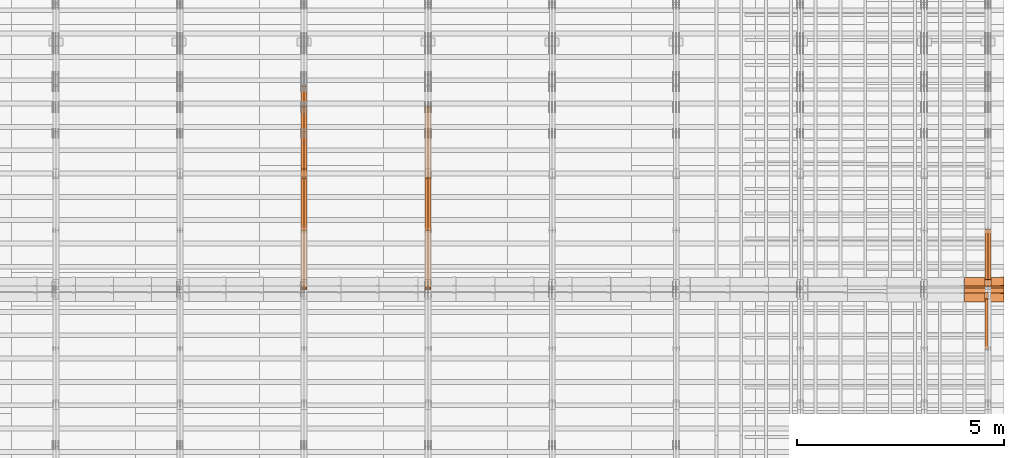
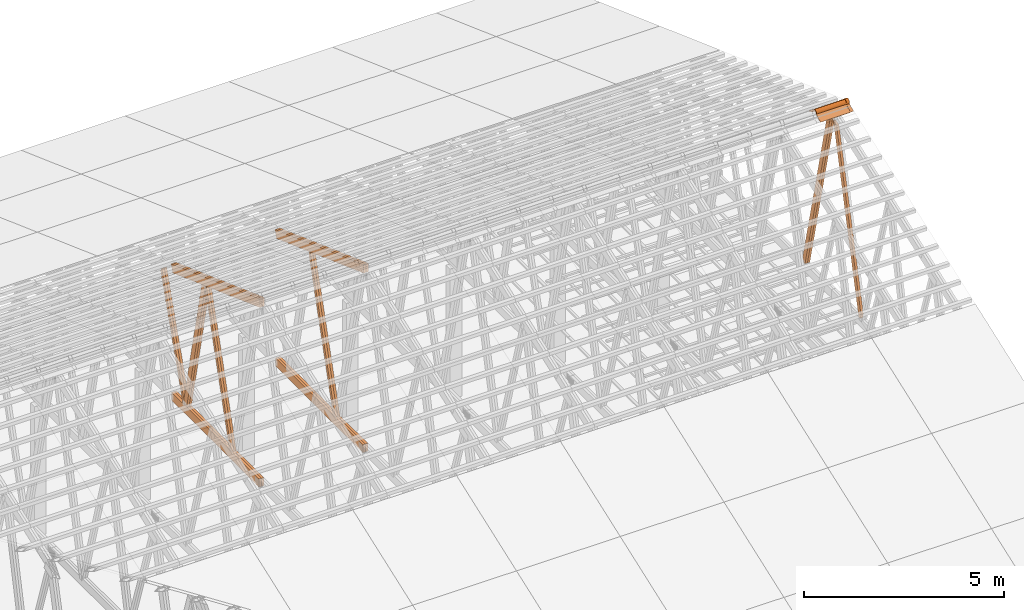
# One storey, part 57 of 189: 21 proxies.
"""IFC2X3 building model written with IfcOpenShell, lengths in millimetres."""

from ifc_helpers import new_model, entity, si_unit, converted_unit, derived_unit, direction, frame, frame_2d, origin, origin_2d_with_axis, place, context, subcontext, project, spatial, polyline, circle_curve, parameter, trimmed, segment, composite_curve, rectangle, outline, extrude, source, transform, mapped, material, type_object, type_shapes, element, save


model = new_model("IFC2X3")

# Units and contexts
model_context = context("Model", 3, precision=0.01, world=origin(), true_north=direction((6.12303176911189e-17, 1.0)))
body_context = subcontext(model_context, "Body", "Model", "MODEL_VIEW")
ifc_project = project(units=[si_unit("LENGTHUNIT", "METRE", prefix="MILLI"), si_unit("AREAUNIT", "SQUARE_METRE"), si_unit("VOLUMEUNIT", "CUBIC_METRE"), converted_unit("PLANEANGLEUNIT", "DEGREE", entity("IfcRatioMeasure", 0.0174532925199433), si_unit("PLANEANGLEUNIT", "RADIAN"), dimensions=[0, 0, 0, 0, 0, 0, 0]), si_unit("MASSUNIT", "GRAM", prefix="KILO"), derived_unit("MASSDENSITYUNIT", [(si_unit("MASSUNIT", "GRAM", prefix="KILO"), 1), (si_unit("LENGTHUNIT", "METRE"), -3)]), si_unit("TIMEUNIT", "SECOND"), si_unit("FREQUENCYUNIT", "HERTZ"), si_unit("THERMODYNAMICTEMPERATUREUNIT", "DEGREE_CELSIUS"), derived_unit("THERMALTRANSMITTANCEUNIT", [(si_unit("MASSUNIT", "GRAM", prefix="KILO"), 1), (si_unit("THERMODYNAMICTEMPERATUREUNIT", "KELVIN"), -1), (si_unit("TIMEUNIT", "SECOND"), -3)]), derived_unit("VOLUMETRICFLOWRATEUNIT", [(si_unit("LENGTHUNIT", "METRE"), 3), (si_unit("TIMEUNIT", "SECOND"), -1)]), si_unit("ELECTRICCURRENTUNIT", "AMPERE"), si_unit("ELECTRICVOLTAGEUNIT", "VOLT"), si_unit("POWERUNIT", "WATT"), si_unit("FORCEUNIT", "NEWTON"), si_unit("ILLUMINANCEUNIT", "LUX"), si_unit("LUMINOUSFLUXUNIT", "LUMEN"), si_unit("LUMINOUSINTENSITYUNIT", "CANDELA"), derived_unit("USERDEFINED", [(si_unit("MASSUNIT", "GRAM", prefix="KILO"), -1), (si_unit("LENGTHUNIT", "METRE"), -2), (si_unit("TIMEUNIT", "SECOND"), 3), (si_unit("LUMINOUSFLUXUNIT", "LUMEN"), 1)]), derived_unit("LINEARVELOCITYUNIT", [(si_unit("LENGTHUNIT", "METRE"), 1), (si_unit("TIMEUNIT", "SECOND"), -1)]), si_unit("PRESSUREUNIT", "PASCAL"), derived_unit("USERDEFINED", [(si_unit("LENGTHUNIT", "METRE"), -2), (si_unit("MASSUNIT", "GRAM", prefix="KILO"), 1), (si_unit("TIMEUNIT", "SECOND"), -2)])], contexts=[model_context])

# Site, building, storey
site_placement = place(None, origin())
site = spatial("IfcSite", under=ifc_project, at=site_placement, CompositionType="ELEMENT")
building_placement = place(site_placement, origin())
building = spatial("IfcBuilding", under=site, at=building_placement, CompositionType="ELEMENT")
storey_placement = place(building_placement, origin())
storey = spatial("IfcBuildingStorey", under=building, at=storey_placement, Name="Default", CompositionType="ELEMENT", Elevation=0.0)

# Proxies
ifc_material_1 = material(Name="IfcSurfaceStyle #273838")
building_element_proxy_type_1 = type_object("IfcBuildingElementProxyType", Name="T1-W5 273836", PredefinedType="NOTDEFINED", material=ifc_material_1)
shared_shape_1 = source(origin(), body_context, "Body", "SweptSolid", [
    extrude(outline(polyline([(-3233.61216530572, -72.4999091305202), (2153.79187521892, -72.4999091305202), (2171.36968478227, -7.18521572819375e-05), (2045.62106208646, 72.4999450565989), (-3137.17045678193, 72.4999450565989), (-3233.61216530572, -72.4999091305202)])), frame((2171.36968478227, 72.500192121173, 0.0), z_axis=(0.0, 0.0, 1.0), x_axis=(-1.0, 0.0, 0.0)), (0.0, 0.0, 1.0), 69.9999999999997),
])
type_shapes(building_element_proxy_type_1, [shared_shape_1])
proxy_1_placement = place(building_placement, frame((49770.0, 13261.0146935344, 262.082919891325), z_axis=(-1.0, 0.0, 0.0), x_axis=(0.0, 0.235625623344066, 0.97184389982328)))
element("IfcBuildingElementProxy", 1, at=proxy_1_placement, inside=storey, type_object=building_element_proxy_type_1, material=ifc_material_1, Name="T1-W5", context=body_context, shape_type="MappedRepresentation", body=[
    mapped(shared_shape_1, transform((0.0, 0.0, 0.0), scale=1.0)),
])
ifc_material_2 = material(Name="IfcSurfaceStyle #273772")
building_element_proxy_type_2 = type_object("IfcBuildingElementProxyType", Name="T1-W5 273770", PredefinedType="NOTDEFINED", material=ifc_material_2)
shared_shape_2 = source(origin(), body_context, "Body", "SweptSolid", [
    extrude(outline(polyline([(-3137.17045678193, -72.5002081306407), (2045.62106208646, -72.5002081306408), (2171.36968478227, 5.58426931168476e-05), (2153.79187521892, 72.5001802092942), (-3233.61216530572, 72.5001802092942), (-3137.17045678193, -72.5002081306407)])), frame((2171.36968478227, 72.5001802092942, 0.0), z_axis=(0.0, 0.0, 1.0), x_axis=(-1.0, 0.0, 0.0)), (0.0, 0.0, 1.0), 69.9999999999997),
])
type_shapes(building_element_proxy_type_2, [shared_shape_2])
proxy_2_placement = place(building_placement, frame((49840.0, 16098.0675635854, 227.917113003597), z_axis=(-1.0, 0.0, 0.0), x_axis=(0.0, -0.235625623344066, 0.971843899823279)))
element("IfcBuildingElementProxy", 2, at=proxy_2_placement, inside=storey, type_object=building_element_proxy_type_2, material=ifc_material_2, Name="T1-W5", context=body_context, shape_type="MappedRepresentation", body=[
    mapped(shared_shape_2, transform((0.0, 0.0, 0.0), scale=1.0)),
])
ifc_material_3 = material(Name="IfcSurfaceStyle #273706")
building_element_proxy_type_3 = type_object("IfcBuildingElementProxyType", Name="T1-W5 273704", PredefinedType="NOTDEFINED", material=ifc_material_3)
shared_shape_3 = source(origin(), body_context, "Body", "SweptSolid", [
    extrude(outline(polyline([(-3137.17045678193, -72.5002081306407), (2045.62106208646, -72.5002081306408), (2171.36968478227, 5.58426931168476e-05), (2153.79187521892, 72.5001802092942), (-3233.61216530572, 72.5001802092942), (-3137.17045678193, -72.5002081306407)])), frame((2171.36968478227, 72.5001802092942, 0.0), z_axis=(0.0, 0.0, 1.0), x_axis=(-1.0, 0.0, 0.0)), (0.0, 0.0, 1.0), 69.9999999999997),
])
type_shapes(building_element_proxy_type_3, [shared_shape_3])
proxy_3_placement = place(building_placement, frame((49770.0, 16098.0675635854, 227.917113003597), z_axis=(-1.0, 0.0, 0.0), x_axis=(0.0, -0.235625623344066, 0.971843899823279)))
element("IfcBuildingElementProxy", 3, at=proxy_3_placement, inside=storey, type_object=building_element_proxy_type_3, material=ifc_material_3, Name="T1-W5", context=body_context, shape_type="MappedRepresentation", body=[
    mapped(shared_shape_3, transform((0.0, 0.0, 0.0), scale=1.0)),
])
ifc_material_4 = material(Name="IfcSurfaceStyle #194558")
building_element_proxy_type_4 = type_object("IfcBuildingElementProxyType", Name="T1-W6 194556", PredefinedType="NOTDEFINED", material=ifc_material_4)
shared_shape_4 = source(origin(), body_context, "Body", "SweptSolid", [
    extrude(outline(polyline([(-2668.68989660745, -47.5002238228721), (1800.72567700045, -47.5002238228721), (1797.68490303083, 0.000158637170537834), (1711.12272493628, 47.5001445042868), (-2640.84340836012, 47.5001445042868), (-2668.68989660745, -47.5002238228721)])), frame((1800.7257704503, 47.5001445042868, 0.0), z_axis=(0.0, 0.0, 1.0), x_axis=(-1.0, 0.0, 0.0)), (0.0, 0.0, 1.0), 69.9999999999997),
])
type_shapes(building_element_proxy_type_4, [shared_shape_4])
proxy_4_placement = place(building_placement, frame((36300.0, 17516.8749791841, 4507.23620831254), z_axis=(-1.0, 0.0, 0.0), x_axis=(0.0, -0.281285983104611, -0.959623986626466)))
element("IfcBuildingElementProxy", 4, at=proxy_4_placement, inside=storey, type_object=building_element_proxy_type_4, material=ifc_material_4, Name="T1-W6", context=body_context, shape_type="MappedRepresentation", body=[
    mapped(shared_shape_4, transform((0.0, 0.0, 0.0), scale=1.0)),
])
ifc_material_5 = material(Name="IfcSurfaceStyle #194492")
building_element_proxy_type_5 = type_object("IfcBuildingElementProxyType", Name="T1-W6 194490", PredefinedType="NOTDEFINED", material=ifc_material_5)
shared_shape_5 = source(origin(), body_context, "Body", "SweptSolid", [
    extrude(outline(polyline([(-2668.68989660745, -47.5002238228721), (1800.72567700045, -47.5002238228721), (1797.68490303083, 0.000158637170537834), (1711.12272493628, 47.5001445042868), (-2640.84340836012, 47.5001445042868), (-2668.68989660745, -47.5002238228721)])), frame((1800.7257704503, 47.5001445042868, 0.0), z_axis=(0.0, 0.0, 1.0), x_axis=(-1.0, 0.0, 0.0)), (0.0, 0.0, 1.0), 69.9999999999997),
])
type_shapes(building_element_proxy_type_5, [shared_shape_5])
proxy_5_placement = place(building_placement, frame((36230.0, 17516.8749791841, 4507.23620831254), z_axis=(-1.0, 0.0, 0.0), x_axis=(0.0, -0.281285983104611, -0.959623986626466)))
element("IfcBuildingElementProxy", 5, at=proxy_5_placement, inside=storey, type_object=building_element_proxy_type_5, material=ifc_material_5, Name="T1-W6", context=body_context, shape_type="MappedRepresentation", body=[
    mapped(shared_shape_5, transform((0.0, 0.0, 0.0), scale=1.0)),
])
ifc_material_6 = material(Name="IfcSurfaceStyle #190784")
building_element_proxy_type_6 = type_object("IfcBuildingElementProxyType", Name="T1-B5 190782", PredefinedType="NOTDEFINED", material=ifc_material_6)
shared_shape_6 = source(origin(), body_context, "Body", "SweptSolid", [
    extrude(rectangle(XDim=4381.5, YDim=245.000000000001, at=origin_2d_with_axis()), frame((2190.75, 122.5, 0.0), z_axis=(0.0, 0.0, 1.0), x_axis=(-1.0, 0.0, 0.0)), (0.0, 0.0, 1.0), 69.9999999999997),
])
type_shapes(building_element_proxy_type_6, [shared_shape_6])
proxy_6_placement = place(building_placement, frame((36300.0, 14780.2587890625, 245.0), z_axis=(-1.0, 0.0, 0.0), x_axis=(0.0, 1.0, 0.0)))
element("IfcBuildingElementProxy", 6, at=proxy_6_placement, inside=storey, type_object=building_element_proxy_type_6, material=ifc_material_6, Name="T1-B5", context=body_context, shape_type="MappedRepresentation", body=[
    mapped(shared_shape_6, transform((0.0, 0.0, 0.0), scale=1.0)),
])
ifc_material_7 = material(Name="IfcSurfaceStyle #190727")
building_element_proxy_type_7 = type_object("IfcBuildingElementProxyType", Name="T1-B5 190725", PredefinedType="NOTDEFINED", material=ifc_material_7)
shared_shape_7 = source(origin(), body_context, "Body", "SweptSolid", [
    extrude(rectangle(XDim=4381.5, YDim=245.000000000001, at=origin_2d_with_axis()), frame((2190.75, 122.5, 0.0), z_axis=(0.0, 0.0, 1.0), x_axis=(-1.0, 0.0, 0.0)), (0.0, 0.0, 1.0), 69.9999999999997),
])
type_shapes(building_element_proxy_type_7, [shared_shape_7])
proxy_7_placement = place(building_placement, frame((36230.0, 14780.2587890625, 245.0), z_axis=(-1.0, 0.0, 0.0), x_axis=(0.0, 1.0, 0.0)))
element("IfcBuildingElementProxy", 7, at=proxy_7_placement, inside=storey, type_object=building_element_proxy_type_7, material=ifc_material_7, Name="T1-B5", context=body_context, shape_type="MappedRepresentation", body=[
    mapped(shared_shape_7, transform((0.0, 0.0, 0.0), scale=1.0)),
])
ifc_material_8 = material(Name="IfcSurfaceStyle #189968")
building_element_proxy_type_8 = type_object("IfcBuildingElementProxyType", Name="T1-T3 189966", PredefinedType="NOTDEFINED", material=ifc_material_8)
shared_shape_8 = source(origin(), body_context, "Body", "SweptSolid", [
    extrude(outline(polyline([(-2386.23525922045, -122.500022994835), (2341.64890001386, -122.500022994835), (2341.64888416412, 122.500022994835), (-2297.06252495753, 122.500022994835), (-2386.23525922045, -122.500022994835)])), frame((2341.64890001386, 122.500051926629, 0.0), z_axis=(0.0, 0.0, 1.0), x_axis=(-1.0, 0.0, 0.0)), (0.0, 0.0, 1.0), 69.9999999999997),
])
type_shapes(building_element_proxy_type_8, [shared_shape_8])
proxy_8_placement = place(building_placement, frame((36300.0, 19108.9628956236, 3921.30465489208), z_axis=(-1.0, 0.0, 0.0), x_axis=(0.0, -0.939692620785908, 0.342020143325669)))
element("IfcBuildingElementProxy", 8, at=proxy_8_placement, inside=storey, type_object=building_element_proxy_type_8, material=ifc_material_8, Name="T1-T3", context=body_context, shape_type="MappedRepresentation", body=[
    mapped(shared_shape_8, transform((0.0, 0.0, 0.0), scale=1.0)),
])
ifc_material_9 = material(Name="IfcSurfaceStyle #189911")
building_element_proxy_type_9 = type_object("IfcBuildingElementProxyType", Name="T1-T3 189909", PredefinedType="NOTDEFINED", material=ifc_material_9)
shared_shape_9 = source(origin(), body_context, "Body", "SweptSolid", [
    extrude(outline(polyline([(-2386.23525922045, -122.500022994835), (2341.64890001386, -122.500022994835), (2341.64888416412, 122.500022994835), (-2297.06252495753, 122.500022994835), (-2386.23525922045, -122.500022994835)])), frame((2341.64890001386, 122.500051926629, 0.0), z_axis=(0.0, 0.0, 1.0), x_axis=(-1.0, 0.0, 0.0)), (0.0, 0.0, 1.0), 69.9999999999997),
])
type_shapes(building_element_proxy_type_9, [shared_shape_9])
proxy_9_placement = place(building_placement, frame((36230.0, 19108.9628956236, 3921.30465489208), z_axis=(-1.0, 0.0, 0.0), x_axis=(0.0, -0.939692620785908, 0.342020143325669)))
element("IfcBuildingElementProxy", 9, at=proxy_9_placement, inside=storey, type_object=building_element_proxy_type_9, material=ifc_material_9, Name="T1-T3", context=body_context, shape_type="MappedRepresentation", body=[
    mapped(shared_shape_9, transform((0.0, 0.0, 0.0), scale=1.0)),
])
ifc_material_10 = material(Name="IfcSurfaceStyle #178768")
building_element_proxy_type_10 = type_object("IfcBuildingElementProxyType", Name="T1-W6 178766", PredefinedType="NOTDEFINED", material=ifc_material_10)
shared_shape_10 = source(origin(), body_context, "Body", "SweptSolid", [
    extrude(outline(polyline([(-2668.68989660745, -47.5002238228721), (1800.72567700045, -47.5002238228721), (1797.68490303083, 0.000158637170537834), (1711.12272493628, 47.5001445042868), (-2640.84340836012, 47.5001445042868), (-2668.68989660745, -47.5002238228721)])), frame((1800.7257704503, 47.5001445042868, 0.0), z_axis=(0.0, 0.0, 1.0), x_axis=(-1.0, 0.0, 0.0)), (0.0, 0.0, 1.0), 69.9999999999997),
])
type_shapes(building_element_proxy_type_10, [shared_shape_10])
proxy_10_placement = place(building_placement, frame((33300.0, 17516.8749791841, 4507.23620831254), z_axis=(-1.0, 0.0, 0.0), x_axis=(0.0, -0.281285983104611, -0.959623986626466)))
element("IfcBuildingElementProxy", 10, at=proxy_10_placement, inside=storey, type_object=building_element_proxy_type_10, material=ifc_material_10, Name="T1-W6", context=body_context, shape_type="MappedRepresentation", body=[
    mapped(shared_shape_10, transform((0.0, 0.0, 0.0), scale=1.0)),
])
ifc_material_11 = material(Name="IfcSurfaceStyle #178702")
building_element_proxy_type_11 = type_object("IfcBuildingElementProxyType", Name="T1-W6 178700", PredefinedType="NOTDEFINED", material=ifc_material_11)
shared_shape_11 = source(origin(), body_context, "Body", "SweptSolid", [
    extrude(outline(polyline([(-2668.68989660745, -47.5002238228721), (1800.72567700045, -47.5002238228721), (1797.68490303083, 0.000158637170537834), (1711.12272493628, 47.5001445042868), (-2640.84340836012, 47.5001445042868), (-2668.68989660745, -47.5002238228721)])), frame((1800.7257704503, 47.5001445042868, 0.0), z_axis=(0.0, 0.0, 1.0), x_axis=(-1.0, 0.0, 0.0)), (0.0, 0.0, 1.0), 69.9999999999997),
])
type_shapes(building_element_proxy_type_11, [shared_shape_11])
proxy_11_placement = place(building_placement, frame((33230.0, 17516.8749791841, 4507.23620831254), z_axis=(-1.0, 0.0, 0.0), x_axis=(0.0, -0.281285983104611, -0.959623986626466)))
element("IfcBuildingElementProxy", 11, at=proxy_11_placement, inside=storey, type_object=building_element_proxy_type_11, material=ifc_material_11, Name="T1-W6", context=body_context, shape_type="MappedRepresentation", body=[
    mapped(shared_shape_11, transform((0.0, 0.0, 0.0), scale=1.0)),
])
ifc_material_12 = material(Name="IfcSurfaceStyle #178504")
building_element_proxy_type_12 = type_object("IfcBuildingElementProxyType", Name="T1-W3 178502", PredefinedType="NOTDEFINED", material=ifc_material_12)
shared_shape_12 = source(origin(), body_context, "Body", "SweptSolid", [
    extrude(outline(polyline([(-2517.58938959787, -85.0001104675026), (1625.445846867, -85.0001104675027), (1768.20563426494, 0.000209440697654673), (1749.48871563991, 85.0000057471538), (-2625.55080717397, 85.0000057471538), (-2517.58938959787, -85.0001104675026)])), frame((1768.2056683344, 85.0000547211315, 0.0), z_axis=(0.0, 0.0, 1.0), x_axis=(-1.0, 0.0, 0.0)), (0.0, 0.0, 1.0), 69.9999999999997),
])
type_shapes(building_element_proxy_type_12, [shared_shape_12])
proxy_12_placement = place(building_placement, frame((33300.0, 18415.3042863408, 226.720947016584), z_axis=(-1.0, 0.0, 0.0), x_axis=(0.0, -0.215047682154604, 0.976603550269982)))
element("IfcBuildingElementProxy", 12, at=proxy_12_placement, inside=storey, type_object=building_element_proxy_type_12, material=ifc_material_12, Name="T1-W3", context=body_context, shape_type="MappedRepresentation", body=[
    mapped(shared_shape_12, transform((0.0, 0.0, 0.0), scale=1.0)),
])
ifc_material_13 = material(Name="IfcSurfaceStyle #178438")
building_element_proxy_type_13 = type_object("IfcBuildingElementProxyType", Name="T1-W3 178436", PredefinedType="NOTDEFINED", material=ifc_material_13)
shared_shape_13 = source(origin(), body_context, "Body", "SweptSolid", [
    extrude(outline(polyline([(-2517.58938959787, -85.0001104675026), (1625.445846867, -85.0001104675027), (1768.20563426494, 0.000209440697654673), (1749.48871563991, 85.0000057471538), (-2625.55080717397, 85.0000057471538), (-2517.58938959787, -85.0001104675026)])), frame((1768.2056683344, 85.0000547211315, 0.0), z_axis=(0.0, 0.0, 1.0), x_axis=(-1.0, 0.0, 0.0)), (0.0, 0.0, 1.0), 69.9999999999997),
])
type_shapes(building_element_proxy_type_13, [shared_shape_13])
proxy_13_placement = place(building_placement, frame((33230.0, 18415.3042863408, 226.720947016584), z_axis=(-1.0, 0.0, 0.0), x_axis=(0.0, -0.215047682154604, 0.976603550269982)))
element("IfcBuildingElementProxy", 13, at=proxy_13_placement, inside=storey, type_object=building_element_proxy_type_13, material=ifc_material_13, Name="T1-W3", context=body_context, shape_type="MappedRepresentation", body=[
    mapped(shared_shape_13, transform((0.0, 0.0, 0.0), scale=1.0)),
])
ifc_material_14 = material(Name="IfcSurfaceStyle #178240")
building_element_proxy_type_14 = type_object("IfcBuildingElementProxyType", Name="T1-W7 178238", PredefinedType="NOTDEFINED", material=ifc_material_14)
shared_shape_14 = source(origin(), body_context, "Body", "SweptSolid", [
    extrude(outline(polyline([(-2189.6662270939, -47.5000140805343), (1475.30081553583, -47.5000140805343), (1473.93388518462, 0.00042343352179337), (1398.58463533215, 47.4998023637734), (-2158.15310895869, 47.4998023637734), (-2189.6662270939, -47.5000140805343)])), frame((1475.30081553583, 47.5004895824757, 0.0), z_axis=(0.0, 0.0, 1.0), x_axis=(-1.0, 0.0, 0.0)), (0.0, 0.0, 1.0), 69.9999999999998),
])
type_shapes(building_element_proxy_type_14, [shared_shape_14])
proxy_14_placement = place(building_placement, frame((33300.0, 19742.3819153401, 3693.66743808885), z_axis=(-1.0, 0.0, 0.0), x_axis=(0.0, -0.314845237923104, -0.949143021971475)))
element("IfcBuildingElementProxy", 14, at=proxy_14_placement, inside=storey, type_object=building_element_proxy_type_14, material=ifc_material_14, Name="T1-W7", context=body_context, shape_type="MappedRepresentation", body=[
    mapped(shared_shape_14, transform((0.0, 0.0, 0.0), scale=1.0)),
])
ifc_material_15 = material(Name="IfcSurfaceStyle #178174")
building_element_proxy_type_15 = type_object("IfcBuildingElementProxyType", Name="T1-W7 178172", PredefinedType="NOTDEFINED", material=ifc_material_15)
shared_shape_15 = source(origin(), body_context, "Body", "SweptSolid", [
    extrude(outline(polyline([(-2189.6662270939, -47.5000140805343), (1475.30081553583, -47.5000140805343), (1473.93388518462, 0.00042343352179337), (1398.58463533215, 47.4998023637734), (-2158.15310895869, 47.4998023637734), (-2189.6662270939, -47.5000140805343)])), frame((1475.30081553583, 47.5004895824757, 0.0), z_axis=(0.0, 0.0, 1.0), x_axis=(-1.0, 0.0, 0.0)), (0.0, 0.0, 1.0), 69.9999999999998),
])
type_shapes(building_element_proxy_type_15, [shared_shape_15])
proxy_15_placement = place(building_placement, frame((33230.0, 19742.3819153401, 3693.66743808885), z_axis=(-1.0, 0.0, 0.0), x_axis=(0.0, -0.314845237923104, -0.949143021971475)))
element("IfcBuildingElementProxy", 15, at=proxy_15_placement, inside=storey, type_object=building_element_proxy_type_15, material=ifc_material_15, Name="T1-W7", context=body_context, shape_type="MappedRepresentation", body=[
    mapped(shared_shape_15, transform((0.0, 0.0, 0.0), scale=1.0)),
])
ifc_material_16 = material(Name="IfcSurfaceStyle #174994")
building_element_proxy_type_16 = type_object("IfcBuildingElementProxyType", Name="T1-B5 174992", PredefinedType="NOTDEFINED", material=ifc_material_16)
shared_shape_16 = source(origin(), body_context, "Body", "SweptSolid", [
    extrude(rectangle(XDim=4381.5, YDim=245.000000000001, at=origin_2d_with_axis()), frame((2190.75, 122.5, 0.0), z_axis=(0.0, 0.0, 1.0), x_axis=(-1.0, 0.0, 0.0)), (0.0, 0.0, 1.0), 69.9999999999997),
])
type_shapes(building_element_proxy_type_16, [shared_shape_16])
proxy_16_placement = place(building_placement, frame((33300.0, 14780.2587890625, 245.0), z_axis=(-1.0, 0.0, 0.0), x_axis=(0.0, 1.0, 0.0)))
element("IfcBuildingElementProxy", 16, at=proxy_16_placement, inside=storey, type_object=building_element_proxy_type_16, material=ifc_material_16, Name="T1-B5", context=body_context, shape_type="MappedRepresentation", body=[
    mapped(shared_shape_16, transform((0.0, 0.0, 0.0), scale=1.0)),
])
ifc_material_17 = material(Name="IfcSurfaceStyle #174937")
building_element_proxy_type_17 = type_object("IfcBuildingElementProxyType", Name="T1-B5 174935", PredefinedType="NOTDEFINED", material=ifc_material_17)
shared_shape_17 = source(origin(), body_context, "Body", "SweptSolid", [
    extrude(rectangle(XDim=4381.5, YDim=245.000000000001, at=origin_2d_with_axis()), frame((2190.75, 122.5, 0.0), z_axis=(0.0, 0.0, 1.0), x_axis=(-1.0, 0.0, 0.0)), (0.0, 0.0, 1.0), 69.9999999999997),
])
type_shapes(building_element_proxy_type_17, [shared_shape_17])
proxy_17_placement = place(building_placement, frame((33230.0, 14780.2587890625, 245.0), z_axis=(-1.0, 0.0, 0.0), x_axis=(0.0, 1.0, 0.0)))
element("IfcBuildingElementProxy", 17, at=proxy_17_placement, inside=storey, type_object=building_element_proxy_type_17, material=ifc_material_17, Name="T1-B5", context=body_context, shape_type="MappedRepresentation", body=[
    mapped(shared_shape_17, transform((0.0, 0.0, 0.0), scale=1.0)),
])
ifc_material_18 = material(Name="IfcSurfaceStyle #174178")
building_element_proxy_type_18 = type_object("IfcBuildingElementProxyType", Name="T1-T3 174176", PredefinedType="NOTDEFINED", material=ifc_material_18)
shared_shape_18 = source(origin(), body_context, "Body", "SweptSolid", [
    extrude(outline(polyline([(-2386.23525922045, -122.500022994835), (2341.64890001386, -122.500022994835), (2341.64888416412, 122.500022994835), (-2297.06252495753, 122.500022994835), (-2386.23525922045, -122.500022994835)])), frame((2341.64890001386, 122.500051926629, 0.0), z_axis=(0.0, 0.0, 1.0), x_axis=(-1.0, 0.0, 0.0)), (0.0, 0.0, 1.0), 69.9999999999997),
])
type_shapes(building_element_proxy_type_18, [shared_shape_18])
proxy_18_placement = place(building_placement, frame((33300.0, 19108.9628956236, 3921.30465489208), z_axis=(-1.0, 0.0, 0.0), x_axis=(0.0, -0.939692620785908, 0.342020143325669)))
element("IfcBuildingElementProxy", 18, at=proxy_18_placement, inside=storey, type_object=building_element_proxy_type_18, material=ifc_material_18, Name="T1-T3", context=body_context, shape_type="MappedRepresentation", body=[
    mapped(shared_shape_18, transform((0.0, 0.0, 0.0), scale=1.0)),
])
ifc_material_19 = material(Name="IfcSurfaceStyle #174121")
building_element_proxy_type_19 = type_object("IfcBuildingElementProxyType", Name="T1-T3 174119", PredefinedType="NOTDEFINED", material=ifc_material_19)
shared_shape_19 = source(origin(), body_context, "Body", "SweptSolid", [
    extrude(outline(polyline([(-2386.23525922045, -122.500022994835), (2341.64890001386, -122.500022994835), (2341.64888416412, 122.500022994835), (-2297.06252495753, 122.500022994835), (-2386.23525922045, -122.500022994835)])), frame((2341.64890001386, 122.500051926629, 0.0), z_axis=(0.0, 0.0, 1.0), x_axis=(-1.0, 0.0, 0.0)), (0.0, 0.0, 1.0), 69.9999999999997),
])
type_shapes(building_element_proxy_type_19, [shared_shape_19])
proxy_19_placement = place(building_placement, frame((33230.0, 19108.9628956236, 3921.30465489208), z_axis=(-1.0, 0.0, 0.0), x_axis=(0.0, -0.939692620785908, 0.342020143325669)))
element("IfcBuildingElementProxy", 19, at=proxy_19_placement, inside=storey, type_object=building_element_proxy_type_19, material=ifc_material_19, Name="T1-T3", context=body_context, shape_type="MappedRepresentation", body=[
    mapped(shared_shape_19, transform((0.0, 0.0, 0.0), scale=1.0)),
])
ifc_material_20 = material()
building_element_proxy_type_20 = type_object("IfcBuildingElementProxyType", Name="P75", PredefinedType="NOTDEFINED", material=ifc_material_20)
shared_shape_20 = source(origin(), body_context, "Body", "SweptSolid", [
    extrude(outline(composite_curve([segment(polyline([(-69.4623915065845, -4.60763114971976), (47.4521071665907, -4.60763114971981)]), True, "CONTINUOUS"), segment(trimmed(circle_curve(frame_2d((119.940978060963, 14.6372018310859), x_axis=(-0.966518278591622, -0.256597773077395)), 75.0), [parameter(6.61555373744412e-13)], [parameter(180.0)], True, "PARAMETER"), True, "CONTINUOUS"), segment(polyline([(192.429848955335, 33.882034811891), (182.764666169419, 31.3160570811166)]), True, "CONTINUOUS"), segment(trimmed(circle_curve(frame_2d((119.940978060963, 14.6372018310859), x_axis=(-0.966518278591622, -0.256597773077395)), 65.0), [parameter(1.06866637297174e-12)], [parameter(180.0)], True, "PARAMETER"), False, "CONTINUOUS"), segment(polyline([(57.1172899525073, -2.04165341894578), (47.4521071665911, 5.39236885028051)]), True, "CONTINUOUS"), segment(polyline([(47.4521071665911, 5.39236885028052), (-70.7672243976422, 5.39236885028094)]), True, "CONTINUOUS"), segment(polyline([(-70.7672243976422, 5.39236885028094), (-194.776190618495, -27.5303655446341)]), True, "CONTINUOUS"), segment(polyline([(-194.776190618495, -27.5303655446341), (-192.210212887721, -37.1955483305503)]), True, "CONTINUOUS"), segment(polyline([(-192.210212887721, -37.1955483305503), (-69.4623915065845, -4.60763114971974)]), True, "CONTINUOUS")], self_intersect=False)), frame((0.0, 106.775760402721, -56.5599052870917), z_axis=(1.0, 0.0, 0.0), x_axis=(0.0, -0.820468487122275, 0.571691754041709)), (0.0, 0.0, 1.0), 867.000000000001),
    extrude(outline(composite_curve([segment(polyline([(62.2906866429439, -18.428943356533), (189.290686642944, -18.428943356533)]), True, "CONTINUOUS"), segment(polyline([(189.290686642944, -18.428943356533), (189.290686642944, -8.42894335653292)]), True, "CONTINUOUS"), segment(polyline([(189.290686642944, -8.42894335653292), (62.2906866429439, -8.42894335653294)]), True, "CONTINUOUS"), segment(polyline([(62.2906866429439, -8.42894335653294), (-41.0348065006093, 19.0026034957362)]), True, "CONTINUOUS"), segment(trimmed(circle_curve(frame_2d((-125.709313357056, 11.5710566434651), x_axis=(1.0, 0.0)), 85.0), [parameter(5.01577186738723)], [parameter(180.0)], True, "PARAMETER"), True, "CONTINUOUS"), segment(polyline([(-210.709313357056, 11.5710566434656), (-200.709313357056, 11.5710566434656)]), True, "CONTINUOUS"), segment(trimmed(circle_curve(frame_2d((-125.709313357056, 11.5710566434651), x_axis=(1.0, 0.0)), 75.0), [parameter(3.05333249420498e-13)], [parameter(180.0)], True, "PARAMETER"), False, "CONTINUOUS"), segment(polyline([(-50.7093133570542, 11.5710566434655), (62.290686642944, -18.4289433565322)]), True, "CONTINUOUS")], self_intersect=False)), frame((867.0, 114.170579674061, -53.8683539143053), z_axis=(1.0, 0.0, 0.0), x_axis=(0.0, 0.939692620785914, -0.342020143325653)), (0.0, 0.0, 1.0), 86.9999999999998),
])
type_shapes(building_element_proxy_type_20, [shared_shape_20])
proxy_20_placement = place(building_placement, frame((49202.9353253273, 14755.0000438631, 5865.69618295448)))
element("IfcBuildingElementProxy", 20, at=proxy_20_placement, inside=storey, type_object=building_element_proxy_type_20, material=ifc_material_20, Name="P75, generic model20:P75", ObjectType="P75, generic model20:P75", context=body_context, shape_type="MappedRepresentation", body=[
    mapped(shared_shape_20, transform((0.0, 0.0, 0.0), scale=1.0)),
])
building_element_proxy_type_21 = type_object("IfcBuildingElementProxyType", Name="P75", PredefinedType="NOTDEFINED", material=ifc_material_20)
shared_shape_21 = source(origin(), body_context, "Body", "SweptSolid", [
    extrude(outline(composite_curve([segment(polyline([(68.3189789579817, 13.3705352460084), (195.318978957982, 13.3705352460084)]), True, "CONTINUOUS"), segment(polyline([(195.318978957982, 13.3705352460084), (195.318978957982, 23.3705352460084)]), True, "CONTINUOUS"), segment(polyline([(195.318978957982, 23.3705352460084), (67.014146066922, 23.3705352460088)]), True, "CONTINUOUS"), segment(polyline([(67.014146066922, 23.3705352460088), (-47.2469987727929, -6.96428196807339)]), True, "CONTINUOUS"), segment(polyline([(-47.2469987727929, -6.96428196807339), (-54.6810210420187, -16.62946475399)]), True, "CONTINUOUS"), segment(trimmed(circle_curve(frame_2d((-119.681021042019, -16.6294647539896), x_axis=(1.0, 0.0)), 65.0), [parameter(180.0)], [parameter(359.999999999999)], True, "PARAMETER"), False, "CONTINUOUS"), segment(polyline([(-184.681021042019, -16.6294647539905), (-194.681021042019, -16.6294647539901)]), True, "CONTINUOUS"), segment(trimmed(circle_curve(frame_2d((-119.681021042019, -16.6294647539896), x_axis=(1.0, 0.0)), 75.0), [parameter(180.0)], [parameter(359.999999999999)], True, "PARAMETER"), True, "CONTINUOUS"), segment(polyline([(-44.6810210420183, -16.6294647539898), (68.3189789579816, 13.3705352460083)]), True, "CONTINUOUS")], self_intersect=False)), frame((0.0, -106.775760402721, -56.5599052870916), z_axis=(1.0, 0.0, 0.0), x_axis=(0.0, -0.939692620785914, -0.342020143325654)), (0.0, 0.0, 1.0), 867.000000000001),
    extrude(outline(composite_curve([segment(polyline([(-64.9339130518847, 1.82825913317695), (-187.681734433021, -30.7596580476538)]), True, "CONTINUOUS"), segment(polyline([(-187.681734433021, -30.7596580476538), (-185.115756702247, -40.4248408335702)]), True, "CONTINUOUS"), segment(polyline([(-185.115756702247, -40.4248408335702), (-62.3679353211107, -7.83692365273935)]), True, "CONTINUOUS"), segment(polyline([(-62.3679353211107, -7.83692365273935), (44.5369162809878, -7.83692365273935)]), True, "CONTINUOUS"), segment(trimmed(circle_curve(frame_2d((124.469456515662, 21.0730921139827), x_axis=(-0.966518278591636, -0.256597773077402)), 85.0), [parameter(5.01577186738723)], [parameter(180.0)], True, "PARAMETER"), True, "CONTINUOUS"), segment(polyline([(206.623510195951, 42.8839028255618), (196.958327410034, 40.3179250947878)]), True, "CONTINUOUS"), segment(trimmed(circle_curve(frame_2d((124.469456515662, 21.0730921139827), x_axis=(-0.966518278591636, -0.256597773077402)), 75.0), [parameter(3.05333249420498e-13)], [parameter(180.0)], True, "PARAMETER"), False, "CONTINUOUS"), segment(polyline([(51.9805856212887, 1.82825913317622), (-64.9339130518846, 1.82825913317621)]), True, "CONTINUOUS")], self_intersect=False)), frame((867.0, -114.170579674061, -53.868353914305), z_axis=(-1.0, 0.0, 0.0), x_axis=(0.0, 0.820468487122275, 0.571691754041709)), (0.0, 0.0, -1.0), 86.9999999999998),
])
type_shapes(building_element_proxy_type_21, [shared_shape_21])
proxy_21_placement = place(storey_placement, frame((49202.9353253273, 14735.8024501427, 5875.96634917334)))
element("IfcBuildingElementProxy", 21, at=proxy_21_placement, inside=storey, type_object=building_element_proxy_type_21, material=ifc_material_20, Name="P75, generic model20:P75", ObjectType="P75, generic model20:P75", context=body_context, shape_type="MappedRepresentation", body=[
    mapped(shared_shape_21, transform((0.0, 0.0, 0.0), scale=1.0)),
])

save(model, "model.ifc")
